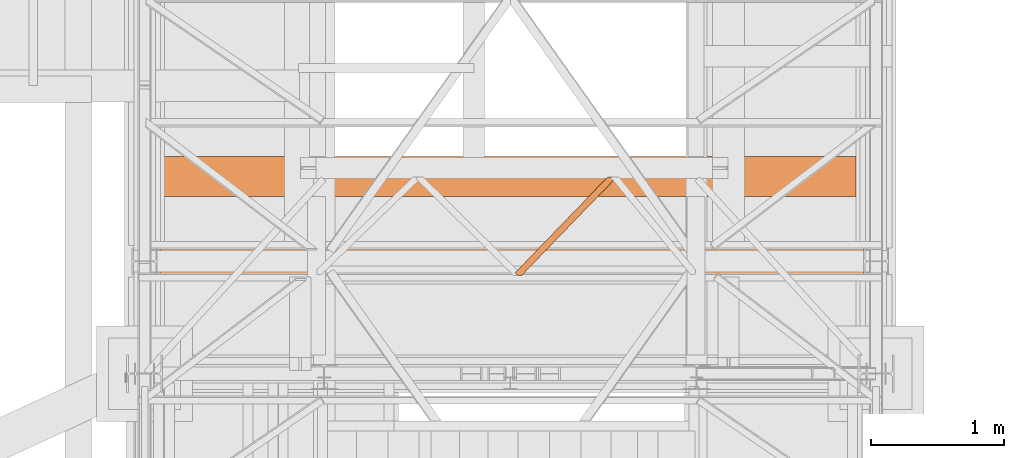
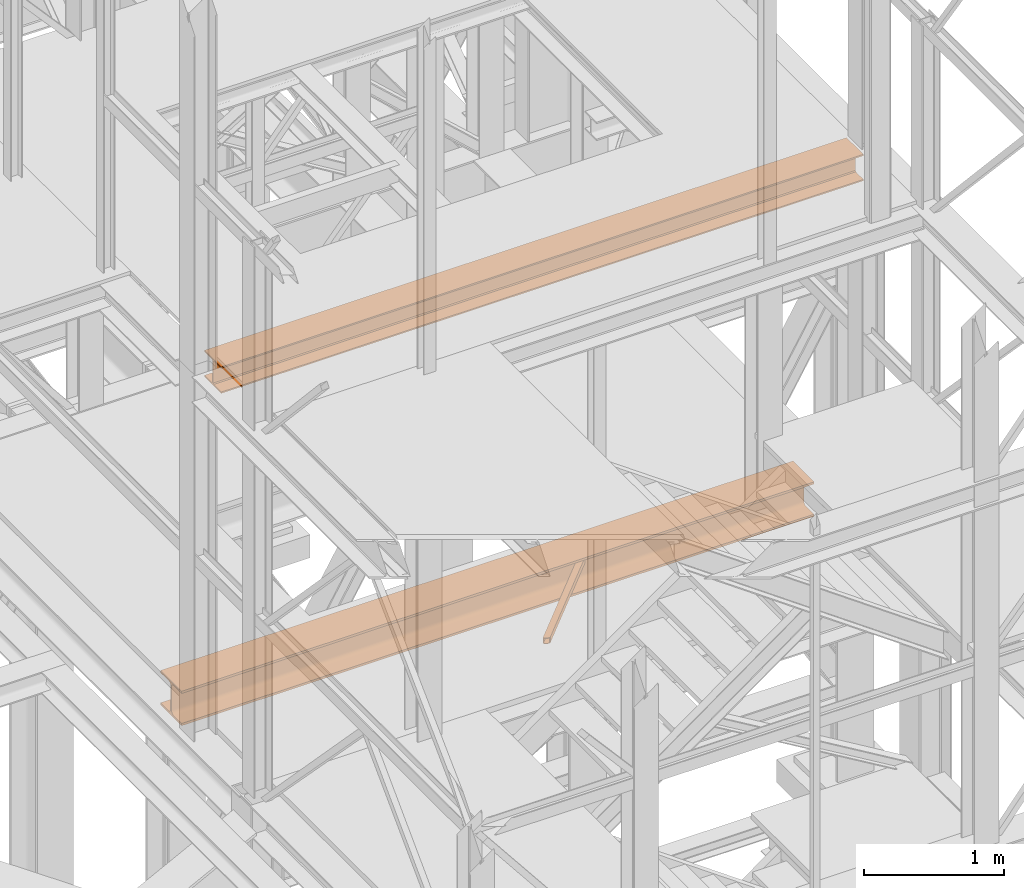
# One storey, part 63 of 208: 3 proxies.
"""IFC2X3 building model written with IfcOpenShell, lengths in millimetres."""

from ifc_helpers import new_model, entity, si_unit, converted_unit, frame, origin, origin_with_axes, place, context, subcontext, project, spatial, faceted_brep, element, save


model = new_model("IFC2X3")

# Units and contexts
model_context = context("Model", 3, precision=1e-05, world=origin())
plan_context = context("Plan", 3, precision=1e-05, world=origin())
body_context = subcontext(model_context, "Body", "Model", "MODEL_VIEW")
ifc_project = project(units=[si_unit("LENGTHUNIT", "METRE", prefix="MILLI"), converted_unit("PLANEANGLEUNIT", "DEGREE", entity("IfcPlaneAngleMeasure", 0.0174532925199433), si_unit("PLANEANGLEUNIT", "RADIAN"), dimensions=[0, 0, 0, 0, 0, 0, 0]), si_unit("AREAUNIT", "SQUARE_METRE"), si_unit("VOLUMEUNIT", "CUBIC_METRE")], contexts=[model_context, plan_context])

# Building, storey
building_placement = place(None, origin())
building = spatial("IfcBuilding", under=ifc_project, at=building_placement, CompositionType="COMPLEX")
storey_placement = place(building_placement, origin_with_axes())
storey = spatial("IfcBuildingStorey", under=building, at=storey_placement, Name="Geschoss", CompositionType="ELEMENT")

# Proxies
proxy_1_placement = place(storey_placement, frame((3982.977170374019, -21323.87439017521, 5124.989999999998), z_axis=(0.0, 0.0, 1.0), x_axis=(1.0, 0.0, 0.0)))
element("IfcBuildingElementProxy", 1, at=proxy_1_placement, inside=storey, context=body_context, shape_type="Brep", body=[
    faceted_brep([(50.79478130679217, 0.01000000000203727, 50.01000000000022), (757.296978527831, 731.5856289512958, 50.01000000000022), (757.296978527831, 731.5856289512958, 0.01000000000021828), (50.79478130679217, 0.01000000000203727, 0.01000000000021828), (50.79478130679217, 0.01000000000203727, 0.01000000000021828), (757.296978527831, 731.5856289512958, 0.01000000000021828), (746.2462508663793, 739.8100000473169, 0.01000000000021828), (696.3000509778785, 739.8100000473169, 0.009999999999308784), (0.009999999999308784, 18.80894162131153, 0.01000000000021828), (25.26931548506309, 0.01000000000203727, 0.01000000000021828), (0.009999999999308784, 18.80894162131153, 0.01000000000021828), (696.3000509778785, 739.8100000473169, 0.009999999999308784), (696.3000509778785, 739.8100000473169, 50.01000000000022), (0.009999999999308784, 18.80894162131153, 50.01000000000022), (0.009999999999308784, 18.80894162131153, 50.01000000000022), (696.3000509778785, 739.8100000473169, 50.01000000000022), (746.2462508663793, 739.8100000473169, 50.01000000000022), (757.296978527831, 731.5856289512958, 50.01000000000022), (50.79478130679217, 0.01000000000203727, 50.01000000000022), (25.26931548506309, 0.01000000000203727, 50.01000000000022), (25.26931548506309, 0.01000000000203727, 0.01000000000021828), (0.009999999999308784, 18.80894162131153, 0.01000000000021828), (0.009999999999308784, 18.80894162131153, 50.01000000000022), (25.26931548506309, 0.01000000000203727, 50.01000000000022), (25.26931548506309, 0.01000000000203727, 46.01000000000022), (3.218853088060314, 16.42079132050276, 46.01000000000022), (3.218853088060314, 16.42079132050276, 4.010000000000218), (25.26931548506309, 0.01000000000203727, 4.010000000000218), (757.296978527831, 731.5856289512958, 50.01000000000022), (746.2462508663793, 739.8100000473169, 50.01000000000022), (746.2462508663793, 739.8100000473132, 46.01000000000022), (754.08812543977, 733.9737792521009, 46.01000000000022), (754.08812543977, 733.9737792521009, 4.010000000000218), (746.2462508663793, 739.8100000473132, 4.010000000000218), (746.2462508663793, 739.8100000473169, 0.01000000000021828), (757.296978527831, 731.5856289512958, 0.01000000000021828), (45.27962745084915, 0.01000000000203727, 4.010000000000218), (754.08812543977, 733.9737792521009, 4.010000000000218), (754.08812543977, 733.9737792521009, 46.01000000000022), (45.27962745084915, 0.01000000000203727, 46.01000000000022), (25.26931548506309, 0.01000000000203727, 4.010000000000218), (3.218853088060314, 16.42079132050276, 4.010000000000218), (701.8152048338216, 739.8100000473169, 4.010000000000218), (746.2462508663793, 739.8100000473132, 4.010000000000218), (754.08812543977, 733.9737792521009, 4.010000000000218), (45.27962745084915, 0.01000000000203727, 4.010000000000218), (3.218853088060314, 16.42079132050276, 4.010000000000218), (3.218853088060314, 16.42079132050276, 46.01000000000022), (701.8152048338216, 739.8100000473169, 46.01000000000022), (701.8152048338216, 739.8100000473169, 4.010000000000218), (3.218853088060314, 16.42079132050276, 46.01000000000022), (25.26931548506309, 0.01000000000203727, 46.01000000000022), (45.27962745084915, 0.01000000000203727, 46.01000000000022), (754.08812543977, 733.9737792521009, 46.01000000000022), (746.2462508663793, 739.8100000473132, 46.01000000000022), (701.8152048338216, 739.8100000473169, 46.01000000000022), (746.2462508663793, 739.8100000473169, 0.01000000000021828), (746.2462508663793, 739.8100000473132, 4.010000000000218), (701.8152048338216, 739.8100000473169, 4.010000000000218), (701.8152048338216, 739.8100000473169, 46.01000000000022), (746.2462508663793, 739.8100000473132, 46.01000000000022), (746.2462508663793, 739.8100000473169, 50.01000000000022), (696.3000509778785, 739.8100000473169, 50.01000000000022), (696.3000509778785, 739.8100000473169, 0.009999999999308784), (50.79478130679217, 0.01000000000203727, 0.01000000000021828), (25.26931548506309, 0.01000000000203727, 0.01000000000021828), (25.26931548506309, 0.01000000000203727, 4.010000000000218), (45.27962745084915, 0.01000000000203727, 4.010000000000218), (45.27962745084915, 0.01000000000203727, 46.01000000000022), (25.26931548506309, 0.01000000000203727, 46.01000000000022), (25.26931548506309, 0.01000000000203727, 50.01000000000022), (50.79478130679217, 0.01000000000203727, 50.01000000000022)], [[[0, 1, 2, 3]], [[4, 5, 6, 7, 8, 9]], [[10, 11, 12, 13]], [[14, 15, 16, 17, 18, 19]], [[20, 21, 22, 23, 24, 25, 26, 27]], [[28, 29, 30, 31, 32, 33, 34, 35]], [[36, 37, 38, 39]], [[40, 41, 42, 43, 44, 45]], [[46, 47, 48, 49]], [[50, 51, 52, 53, 54, 55]], [[56, 57, 58, 59, 60, 61, 62, 63]], [[64, 65, 66, 67, 68, 69, 70, 71]]], orient=[[False], [False], [False], [False], [False], [False], [False], [False], [False], [False], [False], [False]]),
])
proxy_2_placement = place(storey_placement, frame((1343.254973297044, -20728.57439012789, 4984.990005364416), z_axis=(0.0, 0.0, 1.0), x_axis=(1.0, 0.0, 0.0)))
element("IfcBuildingElementProxy", 2, at=proxy_2_placement, inside=storey, context=body_context, shape_type="Brep", body=[
    faceted_brep([(0.01000000000112777, 0.00999999999839929, 300.0100000000002), (5205.009995231621, 0.00999999999839929, 300.0100000000002), (5205.009995231621, 0.00999999999839929, 281.0100000000002), (0.01000000000112777, 0.00999999999839929, 281.0100000000002), (0.01000000000112777, 0.00999999999839929, 281.0100000000002), (5205.009995231621, 0.00999999999839929, 281.0100000000002), (5205.009995231621, 117.5099999999984, 281.0100000000002), (0.01000000000112777, 117.5099999999984, 281.0100000000002), (0.01000000000112777, 117.5099999999984, 281.0100000000002), (5205.009995231621, 117.5099999999984, 281.0100000000002), (5205.009995231621, 124.4980907807731, 280.0899181875066), (0.01000000000112777, 124.4980907807731, 280.0899181875066), (0.01000000000112777, 124.4980907807731, 280.0899181875066), (5205.009995231621, 124.4980907807731, 280.0899181875066), (5205.009995231621, 131.0099606245385, 277.3926133818113), (0.01000000000112777, 131.0099606245385, 277.3926133818113), (0.01000000000112777, 131.0099606245385, 277.3926133818113), (5205.009995231621, 131.0099606245385, 277.3926133818113), (5205.009995231621, 136.6018830920366, 273.1018830920375), (0.01000000000203727, 136.6018830920366, 273.1018830920366), (0.01000000000203727, 136.6018830920366, 273.1018830920366), (5205.009995231621, 136.6018830920366, 273.1018830920375), (5205.009995231621, 140.8926133818095, 267.5099606245422), (0.01000000000021828, 140.8926133818095, 267.5099606245422), (0.01000000000021828, 140.8926133818095, 267.5099606245422), (5205.009995231621, 140.8926133818095, 267.5099606245422), (5205.009995231621, 143.5899181875029, 260.9980907807767), (0.01000000000203727, 143.5899181875029, 260.9980907807767), (0.01000000000203727, 143.5899181875029, 260.9980907807767), (5205.009995231621, 143.5899181875029, 260.9980907807767), (5205.009995231621, 144.5099999999984, 254.0100000000002), (0.01000000000112777, 144.5099999999984, 254.0100000000002), (0.01000000000112777, 144.5099999999984, 254.0100000000002), (5205.009995231621, 144.5099999999984, 254.0100000000002), (5205.009995231621, 144.5099999999984, 46.01000000000022), (0.01000000000112777, 144.5099999999984, 46.01000000000022), (0.01000000000112777, 144.5099999999984, 46.01000000000022), (5205.009995231621, 144.5099999999984, 46.01000000000022), (5205.009995231621, 143.1884339422577, 37.66656945413979), (0.01000000000112777, 143.1884339422577, 37.66656945413979), (0.01000000000112777, 143.1884339422577, 37.66656945413979), (5205.009995231621, 143.1884339422577, 37.66656945413979), (5205.009995231621, 139.3534254633996, 30.13982493419917), (0.01000000000021828, 139.3534254633996, 30.13982493419826), (0.01000000000021828, 139.3534254633996, 30.13982493419826), (5205.009995231621, 139.3534254633996, 30.13982493419917), (5205.009995231621, 133.3801750657985, 24.16657453659809), (0.01000000000112777, 133.3801750657985, 24.16657453659809), (0.01000000000112777, 133.3801750657985, 24.16657453659809), (5205.009995231621, 133.3801750657985, 24.16657453659809), (5205.009995231621, 125.8534305458597, 20.33156605774093), (0.01000000000112777, 125.8534305458597, 20.33156605774093), (0.01000000000112777, 125.8534305458597, 20.33156605774093), (5205.009995231621, 125.8534305458597, 20.33156605774093), (5205.009995231621, 117.5099999999984, 19.01000000000022), (0.01000000000112777, 117.5099999999984, 19.01000000000022), (0.01000000000112777, 117.5099999999984, 19.01000000000022), (5205.009995231621, 117.5099999999984, 19.01000000000022), (5205.009995231621, 0.00999999999839929, 19.01000000000022), (0.01000000000203727, 0.00999999999839929, 19.01000000000022), (0.01000000000203727, 0.00999999999839929, 19.01000000000022), (5205.009995231621, 0.00999999999839929, 19.01000000000022), (5205.009995231621, 0.00999999999839929, 0.01000000000021828), (0.01000000000021828, 0.00999999999839929, 0.01000000000021828), (0.01000000000021828, 0.00999999999839929, 0.01000000000021828), (5205.009995231621, 0.00999999999839929, 0.01000000000021828), (5205.009995231621, 300.0099999999984, 0.01000000000021828), (0.01000000000021828, 300.0099999999984, 0.01000000000021828), (0.01000000000021828, 300.0099999999984, 0.01000000000021828), (5205.009995231621, 300.0099999999984, 0.01000000000021828), (5205.009995231621, 300.0099999999984, 19.01000000000022), (0.01000000000112777, 300.0099999999984, 19.01000000000022), (0.01000000000112777, 300.0099999999984, 19.01000000000022), (5205.009995231621, 300.0099999999984, 19.01000000000022), (5205.009995231621, 182.5099999999984, 19.01000000000022), (0.01000000000203727, 182.5099999999984, 19.01000000000022), (0.01000000000203727, 182.5099999999984, 19.01000000000022), (5205.009995231621, 182.5099999999984, 19.01000000000022), (5205.009995231621, 174.1665694541371, 20.33156605774093), (0.01000000000021828, 174.1665694541371, 20.33156605774093), (0.01000000000021828, 174.1665694541371, 20.33156605774093), (5205.009995231621, 174.1665694541371, 20.33156605774093), (5205.009995231621, 166.6398249341983, 24.16657453659809), (0.01000000000203727, 166.6398249341983, 24.16657453659809), (0.01000000000203727, 166.6398249341983, 24.16657453659809), (5205.009995231621, 166.6398249341983, 24.16657453659809), (5205.009995231621, 160.6665745365972, 30.13982493419917), (0.01000000000112777, 160.6665745365972, 30.13982493419826), (0.01000000000112777, 160.6665745365972, 30.13982493419826), (5205.009995231621, 160.6665745365972, 30.13982493419917), (5205.009995231621, 156.8315660577391, 37.66656945413979), (0.01000000000203727, 156.8315660577391, 37.66656945413888), (0.01000000000203727, 156.8315660577391, 37.66656945413888), (5205.009995231621, 156.8315660577391, 37.66656945413979), (5205.009995231621, 155.5099999999984, 46.01000000000022), (0.01000000000021828, 155.5099999999984, 46.01000000000022), (0.01000000000021828, 155.5099999999984, 46.01000000000022), (5205.009995231621, 155.5099999999984, 46.01000000000022), (5205.009995231621, 155.5099999999984, 254.0100000000002), (0.01000000000021828, 155.5099999999984, 254.0100000000002), (0.01000000000021828, 155.5099999999984, 254.0100000000002), (5205.009995231621, 155.5099999999984, 254.0100000000002), (5205.009995231621, 156.8315660577391, 262.3534305458607), (0.01000000000112777, 156.8315660577391, 262.3534305458607), (0.01000000000112777, 156.8315660577391, 262.3534305458607), (5205.009995231621, 156.8315660577391, 262.3534305458607), (5205.009995231621, 160.6665745365972, 269.8801750658022), (0.01000000000112777, 160.6665745365972, 269.8801750658022), (0.01000000000112777, 160.6665745365972, 269.8801750658022), (5205.009995231621, 160.6665745365972, 269.8801750658022), (5205.009995231621, 166.6398249341983, 275.8534254634024), (0.01000000000021828, 166.6398249341983, 275.8534254634024), (0.01000000000021828, 166.6398249341983, 275.8534254634024), (5205.009995231621, 166.6398249341983, 275.8534254634024), (5205.009995231621, 174.1665694541371, 279.6884339422595), (0.01000000000112777, 174.1665694541371, 279.6884339422595), (0.01000000000112777, 174.1665694541371, 279.6884339422595), (5205.009995231621, 174.1665694541371, 279.6884339422595), (5205.009995231621, 182.5099999999984, 281.0100000000002), (0.01000000000203727, 182.5099999999984, 281.0100000000002), (0.01000000000203727, 182.5099999999984, 281.0100000000002), (5205.009995231621, 182.5099999999984, 281.0100000000002), (5205.009995231621, 300.0099999999984, 281.0100000000002), (0.01000000000112777, 300.0099999999984, 281.0100000000002), (0.01000000000112777, 300.0099999999984, 281.0100000000002), (5205.009995231621, 300.0099999999984, 281.0100000000002), (5205.009995231621, 300.0099999999984, 300.0100000000002), (0.01000000000112777, 300.0099999999984, 300.0100000000002), (0.01000000000112777, 300.0099999999984, 300.0100000000002), (5205.009995231621, 300.0099999999984, 300.0100000000002), (5205.009995231621, 0.00999999999839929, 300.0100000000002), (0.01000000000112777, 0.00999999999839929, 300.0100000000002), (5205.009995231621, 0.00999999999839929, 300.0100000000002), (5205.009995231621, 300.0099999999984, 300.0100000000002), (5205.009995231621, 300.0099999999984, 281.0100000000002), (5205.009995231621, 182.5099999999984, 281.0100000000002), (5205.009995231621, 174.1665694541371, 279.6884339422595), (5205.009995231621, 166.6398249341983, 275.8534254634024), (5205.009995231621, 160.6665745365972, 269.8801750658022), (5205.009995231621, 156.8315660577391, 262.3534305458607), (5205.009995231621, 155.5099999999984, 254.0100000000002), (5205.009995231621, 155.5099999999984, 46.01000000000022), (5205.009995231621, 156.8315660577391, 37.66656945413979), (5205.009995231621, 160.6665745365972, 30.13982493419917), (5205.009995231621, 166.6398249341983, 24.16657453659809), (5205.009995231621, 174.1665694541371, 20.33156605774093), (5205.009995231621, 182.5099999999984, 19.01000000000022), (5205.009995231621, 300.0099999999984, 19.01000000000022), (5205.009995231621, 300.0099999999984, 0.01000000000021828), (5205.009995231621, 0.00999999999839929, 0.01000000000021828), (5205.009995231621, 0.00999999999839929, 19.01000000000022), (5205.009995231621, 117.5099999999984, 19.01000000000022), (5205.009995231621, 125.8534305458597, 20.33156605774093), (5205.009995231621, 133.3801750657985, 24.16657453659809), (5205.009995231621, 139.3534254633996, 30.13982493419917), (5205.009995231621, 143.1884339422577, 37.66656945413979), (5205.009995231621, 144.5099999999984, 46.01000000000022), (5205.009995231621, 144.5099999999984, 254.0100000000002), (5205.009995231621, 143.5899181875029, 260.9980907807767), (5205.009995231621, 140.8926133818095, 267.5099606245422), (5205.009995231621, 136.6018830920366, 273.1018830920375), (5205.009995231621, 131.0099606245385, 277.3926133818113), (5205.009995231621, 124.4980907807731, 280.0899181875066), (5205.009995231621, 117.5099999999984, 281.0100000000002), (5205.009995231621, 0.00999999999839929, 281.0100000000002), (0.01000000000112777, 0.00999999999839929, 281.0100000000002), (0.01000000000112777, 117.5099999999984, 281.0100000000002), (0.01000000000112777, 124.4980907807731, 280.0899181875066), (0.01000000000112777, 131.0099606245385, 277.3926133818113), (0.01000000000203727, 136.6018830920366, 273.1018830920366), (0.01000000000021828, 140.8926133818095, 267.5099606245422), (0.01000000000203727, 143.5899181875029, 260.9980907807767), (0.01000000000112777, 144.5099999999984, 254.0100000000002), (0.01000000000112777, 144.5099999999984, 46.01000000000022), (0.01000000000112777, 143.1884339422577, 37.66656945413979), (0.01000000000021828, 139.3534254633996, 30.13982493419826), (0.01000000000112777, 133.3801750657985, 24.16657453659809), (0.01000000000112777, 125.8534305458597, 20.33156605774093), (0.01000000000112777, 117.5099999999984, 19.01000000000022), (0.01000000000203727, 0.00999999999839929, 19.01000000000022), (0.01000000000021828, 0.00999999999839929, 0.01000000000021828), (0.01000000000021828, 300.0099999999984, 0.01000000000021828), (0.01000000000112777, 300.0099999999984, 19.01000000000022), (0.01000000000203727, 182.5099999999984, 19.01000000000022), (0.01000000000021828, 174.1665694541371, 20.33156605774093), (0.01000000000203727, 166.6398249341983, 24.16657453659809), (0.01000000000112777, 160.6665745365972, 30.13982493419826), (0.01000000000203727, 156.8315660577391, 37.66656945413888), (0.01000000000021828, 155.5099999999984, 46.01000000000022), (0.01000000000021828, 155.5099999999984, 254.0100000000002), (0.01000000000112777, 156.8315660577391, 262.3534305458607), (0.01000000000112777, 160.6665745365972, 269.8801750658022), (0.01000000000021828, 166.6398249341983, 275.8534254634024), (0.01000000000112777, 174.1665694541371, 279.6884339422595), (0.01000000000203727, 182.5099999999984, 281.0100000000002), (0.01000000000112777, 300.0099999999984, 281.0100000000002), (0.01000000000112777, 300.0099999999984, 300.0100000000002), (0.01000000000112777, 0.00999999999839929, 300.0100000000002)], [[[0, 1, 2, 3]], [[4, 5, 6, 7]], [[8, 9, 10, 11]], [[12, 13, 14, 15]], [[16, 17, 18, 19]], [[20, 21, 22, 23]], [[24, 25, 26, 27]], [[28, 29, 30, 31]], [[32, 33, 34, 35]], [[36, 37, 38, 39]], [[40, 41, 42, 43]], [[44, 45, 46, 47]], [[48, 49, 50, 51]], [[52, 53, 54, 55]], [[56, 57, 58, 59]], [[60, 61, 62, 63]], [[64, 65, 66, 67]], [[68, 69, 70, 71]], [[72, 73, 74, 75]], [[76, 77, 78, 79]], [[80, 81, 82, 83]], [[84, 85, 86, 87]], [[88, 89, 90, 91]], [[92, 93, 94, 95]], [[96, 97, 98, 99]], [[100, 101, 102, 103]], [[104, 105, 106, 107]], [[108, 109, 110, 111]], [[112, 113, 114, 115]], [[116, 117, 118, 119]], [[120, 121, 122, 123]], [[124, 125, 126, 127]], [[128, 129, 130, 131]], [[132, 133, 134, 135, 136, 137, 138, 139, 140, 141, 142, 143, 144, 145, 146, 147, 148, 149, 150, 151, 152, 153, 154, 155, 156, 157, 158, 159, 160, 161, 162, 163, 164]], [[165, 166, 167, 168, 169, 170, 171, 172, 173, 174, 175, 176, 177, 178, 179, 180, 181, 182, 183, 184, 185, 186, 187, 188, 189, 190, 191, 192, 193, 194, 195, 196, 197]]], orient=[[False], [False], [False], [False], [False], [False], [False], [False], [False], [False], [False], [False], [False], [False], [False], [False], [False], [False], [False], [False], [False], [False], [False], [False], [False], [False], [False], [False], [False], [False], [False], [False], [False], [False], [False]]),
])
proxy_3_placement = place(storey_placement, frame((1318.254973297033, -21337.57439508626, 8254.989997913835), z_axis=(0.0, 0.0, 1.0), x_axis=(1.0, 0.0, 0.0)))
element("IfcBuildingElementProxy", 3, at=proxy_3_placement, inside=storey, context=body_context, shape_type="Brep", body=[
    faceted_brep([(5285.009980298099, 0.00999999999839929, 230.0100041723217), (0.01000000000294676, 0.00999999999839929, 230.0100041723217), (0.01000000000294676, 240.0100095367416, 230.0100041723217), (5285.0099802981, 240.0100095367416, 230.0100041723217), (5285.0099802981, 240.0100095367416, 230.0100041723217), (0.01000000000294676, 240.0100095367416, 230.0100041723217), (0.01000000000294676, 240.0100095367416, 218.0100022053684), (5285.0099802981, 240.0100095367416, 218.0100022053703), (5285.0099802981, 240.0100095367416, 218.0100022053703), (0.01000000000294676, 240.0100095367416, 218.0100022053684), (0.01000000000203727, 144.7600064969047, 218.0100022053684), (5285.009980298099, 144.7600064969047, 218.0100022053684), (5285.009980298099, 144.7600064969047, 218.0100022053684), (0.01000000000203727, 144.7600064969047, 218.0100022053684), (0.01000000000294676, 133.8915605267866, 215.8347008919682), (5285.009980298099, 133.8915605267866, 215.8347008919682), (5285.009980298099, 133.8915605267866, 215.8347008919682), (0.01000000000294676, 133.8915605267866, 215.8347008919682), (0.01000000000203727, 125.9353108873947, 207.8784493899311), (5285.009980298099, 125.9353108873947, 207.8784493899311), (5285.009980298099, 125.9353108873947, 207.8784493899311), (0.01000000000203727, 125.9353108873947, 207.8784493899311), (0.01000000000294676, 123.7600049173816, 197.0100043511357), (5285.009980298099, 123.7600049173816, 197.0100043511357), (5285.009980298099, 123.7600049173816, 197.0100043511357), (0.01000000000294676, 123.7600049173816, 197.0100043511357), (0.01000000000203727, 123.7600049173816, 33.00999982118628), (5285.009980298099, 123.7600049173816, 33.00999982118628), (5285.009980298099, 123.7600049173816, 33.00999982118628), (0.01000000000203727, 123.7600049173816, 33.00999982118628), (0.01000000000021828, 125.9353108873947, 22.14155478239081), (5285.009980298099, 125.9353108873947, 22.14155478239081), (5285.009980298099, 125.9353108873947, 22.14155478239081), (0.01000000000021828, 125.9353108873947, 22.14155478239081), (0.01000000000021828, 133.8915605267866, 14.18530328035376), (5285.009980298099, 133.8915605267866, 14.18530328035376), (5285.009980298099, 133.8915605267866, 14.18530328035376), (0.01000000000021828, 133.8915605267866, 14.18530328035376), (0.01000000000294676, 144.7600064969047, 12.0100019669535), (5285.0099802981, 144.7600064969047, 12.01000196695168), (5285.0099802981, 144.7600064969047, 12.01000196695168), (0.01000000000294676, 144.7600064969047, 12.0100019669535), (0.01000000000203727, 240.0100095367416, 12.0100019669535), (5285.0099802981, 240.0100095367416, 12.01000196695168), (5285.0099802981, 240.0100095367416, 12.01000196695168), (0.01000000000203727, 240.0100095367416, 12.0100019669535), (0.01000000000294676, 240.0100095367416, 0.01000000000021828), (5285.0099802981, 240.0100095367416, 0.01000000000021828), (5285.0099802981, 240.0100095367416, 0.01000000000021828), (0.01000000000294676, 240.0100095367416, 0.01000000000021828), (0.01000000000203727, 0.00999999999839929, 0.01000000000021828), (5285.009980298099, 0.00999999999839929, 0.01000000000021828), (5285.009980298099, 0.00999999999839929, 0.01000000000021828), (0.01000000000203727, 0.00999999999839929, 0.01000000000021828), (0.01000000000203727, 0.00999999999839929, 12.0100019669535), (5285.009980298099, 0.00999999999839929, 12.0100019669535), (5285.009980298099, 0.00999999999839929, 12.0100019669535), (0.01000000000203727, 0.00999999999839929, 12.0100019669535), (0.01000000000203727, 95.26000303983528, 12.0100019669535), (5285.009980298099, 95.26000303983528, 12.0100019669535), (5285.009980298099, 95.26000303983528, 12.0100019669535), (0.01000000000203727, 95.26000303983528, 12.0100019669535), (0.01000000000203727, 106.1284490099533, 14.18530328035376), (5285.009980298099, 106.1284490099533, 14.18530328035376), (5285.009980298099, 106.1284490099533, 14.18530328035376), (0.01000000000203727, 106.1284490099533, 14.18530328035376), (0.01000000000021828, 114.0846986493452, 22.14155478239081), (5285.009980298099, 114.0846986493452, 22.14155478239081), (5285.009980298099, 114.0846986493452, 22.14155478239081), (0.01000000000021828, 114.0846986493452, 22.14155478239081), (0.01000000000203727, 116.2600046193584, 33.00999982118628), (5285.009980298099, 116.2600046193584, 33.00999982118628), (5285.009980298099, 116.2600046193584, 33.00999982118628), (0.01000000000203727, 116.2600046193584, 33.00999982118628), (0.01000000000294676, 116.2600046193584, 197.0100043511357), (5285.009980298099, 116.2600046193584, 197.0100043511357), (5285.009980298099, 116.2600046193584, 197.0100043511357), (0.01000000000294676, 116.2600046193584, 197.0100043511357), (0.01000000000203727, 114.0846986493452, 207.8784493899311), (5285.009980298099, 114.0846986493452, 207.8784493899311), (5285.009980298099, 114.0846986493452, 207.8784493899311), (0.01000000000203727, 114.0846986493452, 207.8784493899311), (0.01000000000203727, 106.1284490099533, 215.8347008919682), (5285.009980298099, 106.1284490099533, 215.8347008919682), (5285.009980298099, 106.1284490099533, 215.8347008919682), (0.01000000000203727, 106.1284490099533, 215.8347008919682), (0.01000000000294676, 95.26000303983528, 218.0100022053684), (5285.009980298099, 95.26000303983528, 218.0100022053684), (5285.009980298099, 95.26000303983528, 218.0100022053684), (0.01000000000294676, 95.26000303983528, 218.0100022053684), (0.01000000000203727, 0.00999999999839929, 218.0100022053684), (5285.009980298099, 0.00999999999839929, 218.0100022053684), (5285.009980298099, 0.00999999999839929, 218.0100022053684), (0.01000000000203727, 0.00999999999839929, 218.0100022053684), (0.01000000000294676, 0.00999999999839929, 230.0100041723217), (5285.009980298099, 0.00999999999839929, 230.0100041723217), (5285.009980298099, 0.00999999999839929, 0.01000000000021828), (5285.009980298099, 0.00999999999839929, 12.0100019669535), (5285.009980298099, 95.26000303983528, 12.0100019669535), (5285.009980298099, 106.1284490099533, 14.18530328035376), (5285.009980298099, 114.0846986493452, 22.14155478239081), (5285.009980298099, 116.2600046193584, 33.00999982118628), (5285.009980298099, 116.2600046193584, 197.0100043511357), (5285.009980298099, 114.0846986493452, 207.8784493899311), (5285.009980298099, 106.1284490099533, 215.8347008919682), (5285.009980298099, 95.26000303983528, 218.0100022053684), (5285.009980298099, 0.00999999999839929, 218.0100022053684), (5285.009980298099, 0.00999999999839929, 230.0100041723217), (5285.0099802981, 240.0100095367416, 230.0100041723217), (5285.0099802981, 240.0100095367416, 218.0100022053703), (5285.009980298099, 144.7600064969047, 218.0100022053684), (5285.009980298099, 133.8915605267866, 215.8347008919682), (5285.009980298099, 125.9353108873947, 207.8784493899311), (5285.009980298099, 123.7600049173816, 197.0100043511357), (5285.009980298099, 123.7600049173816, 33.00999982118628), (5285.009980298099, 125.9353108873947, 22.14155478239081), (5285.009980298099, 133.8915605267866, 14.18530328035376), (5285.0099802981, 144.7600064969047, 12.01000196695168), (5285.0099802981, 240.0100095367416, 12.01000196695168), (5285.0099802981, 240.0100095367416, 0.01000000000021828), (0.01000000000203727, 0.00999999999839929, 0.01000000000021828), (0.01000000000294676, 240.0100095367416, 0.01000000000021828), (0.01000000000203727, 240.0100095367416, 12.0100019669535), (0.01000000000294676, 144.7600064969047, 12.0100019669535), (0.01000000000021828, 133.8915605267866, 14.18530328035376), (0.01000000000021828, 125.9353108873947, 22.14155478239081), (0.01000000000203727, 123.7600049173816, 33.00999982118628), (0.01000000000294676, 123.7600049173816, 197.0100043511357), (0.01000000000203727, 125.9353108873947, 207.8784493899311), (0.01000000000294676, 133.8915605267866, 215.8347008919682), (0.01000000000203727, 144.7600064969047, 218.0100022053684), (0.01000000000294676, 240.0100095367416, 218.0100022053684), (0.01000000000294676, 240.0100095367416, 230.0100041723217), (0.01000000000294676, 0.00999999999839929, 230.0100041723217), (0.01000000000203727, 0.00999999999839929, 218.0100022053684), (0.01000000000294676, 95.26000303983528, 218.0100022053684), (0.01000000000203727, 106.1284490099533, 215.8347008919682), (0.01000000000203727, 114.0846986493452, 207.8784493899311), (0.01000000000294676, 116.2600046193584, 197.0100043511357), (0.01000000000203727, 116.2600046193584, 33.00999982118628), (0.01000000000021828, 114.0846986493452, 22.14155478239081), (0.01000000000203727, 106.1284490099533, 14.18530328035376), (0.01000000000203727, 95.26000303983528, 12.0100019669535), (0.01000000000203727, 0.00999999999839929, 12.0100019669535)], [[[0, 1, 2, 3]], [[4, 5, 6, 7]], [[8, 9, 10, 11]], [[12, 13, 14, 15]], [[16, 17, 18, 19]], [[20, 21, 22, 23]], [[24, 25, 26, 27]], [[28, 29, 30, 31]], [[32, 33, 34, 35]], [[36, 37, 38, 39]], [[40, 41, 42, 43]], [[44, 45, 46, 47]], [[48, 49, 50, 51]], [[52, 53, 54, 55]], [[56, 57, 58, 59]], [[60, 61, 62, 63]], [[64, 65, 66, 67]], [[68, 69, 70, 71]], [[72, 73, 74, 75]], [[76, 77, 78, 79]], [[80, 81, 82, 83]], [[84, 85, 86, 87]], [[88, 89, 90, 91]], [[92, 93, 94, 95]], [[96, 97, 98, 99, 100, 101, 102, 103, 104, 105, 106, 107, 108, 109, 110, 111, 112, 113, 114, 115, 116, 117, 118, 119]], [[120, 121, 122, 123, 124, 125, 126, 127, 128, 129, 130, 131, 132, 133, 134, 135, 136, 137, 138, 139, 140, 141, 142, 143]]], orient=[[False], [False], [False], [False], [False], [False], [False], [False], [False], [False], [False], [False], [False], [False], [False], [False], [False], [False], [False], [False], [False], [False], [False], [False], [False], [False]]),
])

save(model, "model.ifc")
